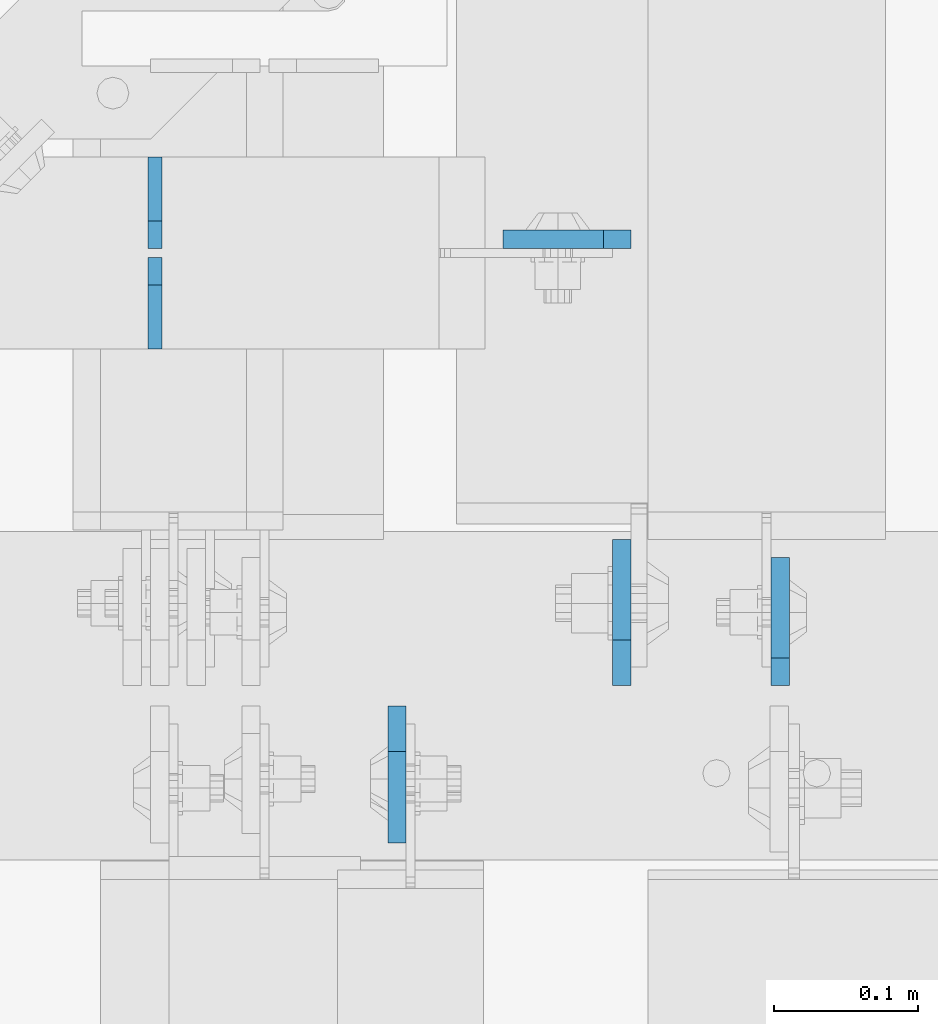
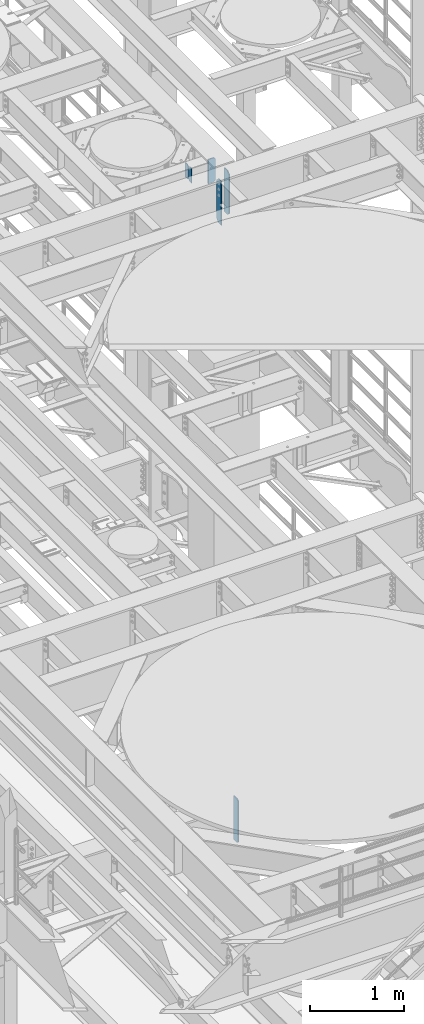
# One storey, part 1582 of 1876: 6 plates, 4 elements without a shape of their own.
"""IFC2X3 building model written with IfcOpenShell, lengths in millimetres."""

from ifc_helpers import new_model, si_unit, frame, origin_with_axes, place, context, subcontext, project, spatial, faceted_brep, material, type_object, element, aggregate, save


model = new_model("IFC2X3")

# Units and contexts
model_context = context("Model", 3, precision=1e-05, world=origin_with_axes())
body_context = subcontext(model_context, "Body", "Model", "MODEL_VIEW")
ifc_project = project(units=[si_unit("LENGTHUNIT", "METRE", prefix="MILLI"), si_unit("AREAUNIT", "SQUARE_METRE"), si_unit("VOLUMEUNIT", "CUBIC_METRE"), si_unit("MASSUNIT", "GRAM", prefix="KILO"), si_unit("TIMEUNIT", "SECOND"), si_unit("PLANEANGLEUNIT", "RADIAN"), si_unit("SOLIDANGLEUNIT", "STERADIAN"), si_unit("THERMODYNAMICTEMPERATUREUNIT", "DEGREE_CELSIUS"), si_unit("LUMINOUSINTENSITYUNIT", "LUMEN")], contexts=[model_context])

# Site, building, storey
site_placement = place(None, origin_with_axes())
site = spatial("IfcSite", under=ifc_project, at=site_placement, CompositionType="ELEMENT")
building_placement = place(site_placement, origin_with_axes())
building = spatial("IfcBuilding", under=site, at=building_placement, Name="Undefined", CompositionType="ELEMENT")
storey_placement = place(building_placement, origin_with_axes())
storey = spatial("IfcBuildingStorey", under=building, at=storey_placement, Name="Undefined", CompositionType="ELEMENT", Elevation=0.0)

# Assembly, plates
assembly_1_placement = place(storey_placement, origin_with_axes())
assembly_1 = element("IfcElementAssembly", 1, at=assembly_1_placement, inside=storey, Name="BEAM", AssemblyPlace="NOTDEFINED", PredefinedType="RIGID_FRAME")
ifc_material = material(Name="STEEL/A36")
plate_type_1 = type_object("IfcPlateType", PredefinedType="NOTDEFINED")
plate_1_placement = place(assembly_1_placement, frame((4749.8, 1765.3, 13111.1625), z_axis=(0.0, 0.0, 1.0), x_axis=(0.0, 1.0, 0.0)))
plate_1 = element("IfcPlate", 2, at=plate_1_placement, type_object=plate_type_1, material=ifc_material, Name="PLATE", context=body_context, shape_type="Brep", body=[
    faceted_brep([(0.0, -4.76249999999982, 0.0), (0.0, -4.76249999999982, 190.5), (0.0, 4.76249999999982, 190.5), (0.0, 4.76249999999982, 0.0), (44.4500007629395, -4.76249999999982, 190.5), (44.4500007629395, 4.76249999999982, 190.5), (63.5, -4.76249999999982, 171.450000762939), (63.5, 4.76249999999982, 171.450000762939), (63.5, -4.76249999999982, 19.0499992370605), (63.5, 4.76249999999982, 19.0499992370605), (44.4500007629395, -4.76249999999982, 0.0), (44.4500007629395, 4.76249999999982, 0.0)], [[[0, 1, 2, 3]], [[1, 4, 5, 2]], [[4, 6, 7, 5]], [[6, 8, 9, 7]], [[8, 10, 11, 9]], [[10, 0, 3, 11]], [[5, 7, 9, 11, 3, 2]], [[10, 8, 6, 4, 1, 0]]]),
])
plate_2_placement = place(assembly_1_placement, frame((4749.8, 1835.15, 13111.1625), z_axis=(0.0, 0.0, 1.0), x_axis=(0.0, 1.0, 0.0)))
plate_2 = element("IfcPlate", 3, at=plate_2_placement, type_object=plate_type_1, material=ifc_material, Name="PLATE", context=body_context, shape_type="Brep", body=[
    faceted_brep([(0.0, -4.76249999999982, 19.0499992370605), (0.0, -4.76249999999982, 171.450000762939), (0.0, 4.76249999999982, 171.450000762939), (0.0, 4.76249999999982, 19.0499992370605), (19.0499992370605, -4.76249999999982, 190.5), (19.0499992370605, 4.76249999999982, 190.5), (63.5, -4.76249999999982, 190.5), (63.5, 4.76249999999982, 190.5), (63.5, -4.76249999999982, 0.0), (63.5, 4.76249999999982, 0.0), (19.0499992370605, -4.76249999999982, 0.0), (19.0499992370605, 4.76249999999982, 0.0)], [[[0, 1, 2, 3]], [[1, 4, 5, 2]], [[4, 6, 7, 5]], [[6, 8, 9, 7]], [[8, 10, 11, 9]], [[10, 0, 3, 11]], [[5, 7, 9, 11, 3, 2]], [[10, 8, 6, 4, 1, 0]]]),
])
aggregate(assembly_1, [plate_1, plate_2])

# Assembly, plate
assembly_2_placement = place(storey_placement, origin_with_axes())
assembly_2 = element("IfcElementAssembly", 4, at=assembly_2_placement, inside=storey, Name="BEAM", AssemblyPlace="NOTDEFINED", PredefinedType="RIGID_FRAME")
plate_type_2 = type_object("IfcPlateType", PredefinedType="NOTDEFINED")
plate_3_placement = place(assembly_2_placement, frame((5184.77442290778, 1531.14375248285, 4535.4875), z_axis=(0.0, 0.0, 1.0), x_axis=(0.0, 1.0, 0.0)))
plate_3 = element("IfcPlate", 5, at=plate_3_placement, type_object=plate_type_2, material=ifc_material, Name="PLATE", context=body_context, shape_type="Brep", body=[
    faceted_brep([(0.0, -6.35000000000196, 19.0499992370605), (0.0, -6.34999999999991, 550.862476348877), (0.0, 6.34999999999991, 550.862476348877), (0.0, 6.35000000000105, 19.0499992370605), (19.0499992370605, -6.34999999999991, 569.912475585938), (19.0499992370605, 6.34999999999991, 569.912475585938), (88.9000015258616, -6.35000000001173, 569.912475585938), (88.9000015258634, 6.34999999998627, 569.912475585938), (88.9000015258789, -6.34999999999991, 0.0), (88.9000015258789, 6.34999999999991, 0.0), (19.0499992370642, -6.35000000000105, 0.0), (19.0499992370633, 6.35000000000105, 0.0)], [[[0, 1, 2, 3]], [[1, 4, 5, 2]], [[4, 6, 7, 5]], [[6, 8, 9, 7]], [[8, 10, 11, 9]], [[10, 0, 3, 11]], [[5, 7, 9, 11, 3, 2]], [[10, 8, 6, 4, 1, 0]]]),
])
aggregate(assembly_2, [plate_3])

assembly_3_placement = place(storey_placement, origin_with_axes())
assembly_3 = element("IfcElementAssembly", 6, at=assembly_3_placement, inside=storey, Name="BEAM", AssemblyPlace="NOTDEFINED", PredefinedType="RIGID_FRAME")
plate_4_placement = place(assembly_3_placement, frame((5080.79375, 1841.50000009537, 12974.6375), z_axis=(0.0, 0.0, 1.0), x_axis=(-1.0, 0.0, 0.0)))
plate_4 = element("IfcPlate", 7, at=plate_4_placement, type_object=plate_type_2, material=ifc_material, Name="PLATE", context=body_context, shape_type="Brep", body=[
    faceted_brep([(0.0, -6.35000000000196, 19.0499992370605), (-9.09494701772928e-13, -6.34999999999764, 296.862506866455), (1.81898940354586e-12, 6.34999999999786, 296.862506866455), (0.0, 6.35000000000105, 19.0499992370605), (19.0499992370587, -6.34999999999604, 315.912506103516), (19.0499992370624, 6.34999999999945, 315.912506103516), (88.9000015258789, -6.34999999999991, 315.912506103516), (88.9000015258789, 6.34999999999991, 315.912506103516), (88.9000015258789, -6.34999999999991, 0.0), (88.9000015258789, 6.34999999999991, 0.0), (19.0499992370642, -6.35000000000105, 0.0), (19.0499992370633, 6.35000000000105, 0.0)], [[[0, 1, 2, 3]], [[1, 4, 5, 2]], [[4, 6, 7, 5]], [[6, 8, 9, 7]], [[8, 10, 11, 9]], [[10, 0, 3, 11]], [[5, 7, 9, 11, 3, 2]], [[10, 8, 6, 4, 1, 0]]]),
])
aggregate(assembly_3, [plate_4])

# Assembly, plates
assembly_4_placement = place(storey_placement, origin_with_axes())
assembly_4 = element("IfcElementAssembly", 8, at=assembly_4_placement, inside=storey, Name="BEAM", AssemblyPlace="NOTDEFINED", PredefinedType="RIGID_FRAME")
plate_type_3 = type_object("IfcPlateType", PredefinedType="NOTDEFINED")
plate_5_placement = place(assembly_4_placement, frame((4918.07499990463, 1516.85625, 12714.2875), z_axis=(0.0, 0.0, 1.0), x_axis=(0.0, -1.0, 0.0)))
plate_5 = element("IfcPlate", 9, at=plate_5_placement, type_object=plate_type_3, material=ifc_material, Name="PLATE", context=body_context, shape_type="Brep", body=[
    faceted_brep([(0.0, -6.34999999999991, 31.75), (0.0, -6.35000000000036, 538.162475585938), (0.0, 6.35000000000036, 538.162475585938), (0.0, 6.34999999999991, 31.75), (31.75, -6.35000000000036, 569.912475585938), (31.75, 6.35000000000036, 569.912475585938), (95.25, -6.35000000000036, 569.912475585938), (95.25, 6.35000000000036, 569.912475585938), (95.25, -6.35000000000036, 0.0), (95.25, 6.35000000000036, 0.0), (31.75, -6.34999999999991, 0.0), (31.75, 6.34999999999991, 0.0)], [[[0, 1, 2, 3]], [[1, 4, 5, 2]], [[4, 6, 7, 5]], [[6, 8, 9, 7]], [[8, 10, 11, 9]], [[10, 0, 3, 11]], [[5, 7, 9, 11, 3, 2]], [[10, 8, 6, 4, 1, 0]]]),
])
plate_type_4 = type_object("IfcPlateType", PredefinedType="NOTDEFINED")
plate_6_placement = place(assembly_4_placement, frame((5074.44374990463, 1531.14375, 12714.2875), z_axis=(0.0, 0.0, 1.0), x_axis=(0.0, 1.0, 0.0)))
plate_6 = element("IfcPlate", 10, at=plate_6_placement, type_object=plate_type_4, material=ifc_material, Name="PLATE", context=body_context, shape_type="Brep", body=[
    faceted_brep([(0.0, -6.34999999999991, 31.75), (0.0, -6.35000000000036, 538.162475585938), (0.0, 6.35000000000036, 538.162475585938), (0.0, 6.34999999999991, 31.75), (31.75, -6.35000000000036, 569.912475585938), (31.75, 6.35000000000036, 569.912475585938), (101.599998474121, -6.34999999999991, 569.912475585938), (101.599998474121, 6.34999999999991, 569.912475585938), (101.599998474121, -6.35000000000036, 0.0), (101.599998474121, 6.35000000000036, 0.0), (31.75, -6.34999999999991, 0.0), (31.75, 6.34999999999991, 0.0)], [[[0, 1, 2, 3]], [[1, 4, 5, 2]], [[4, 6, 7, 5]], [[6, 8, 9, 7]], [[8, 10, 11, 9]], [[10, 0, 3, 11]], [[5, 7, 9, 11, 3, 2]], [[10, 8, 6, 4, 1, 0]]]),
])
aggregate(assembly_4, [plate_6, plate_5])

save(model, "model.ifc")
